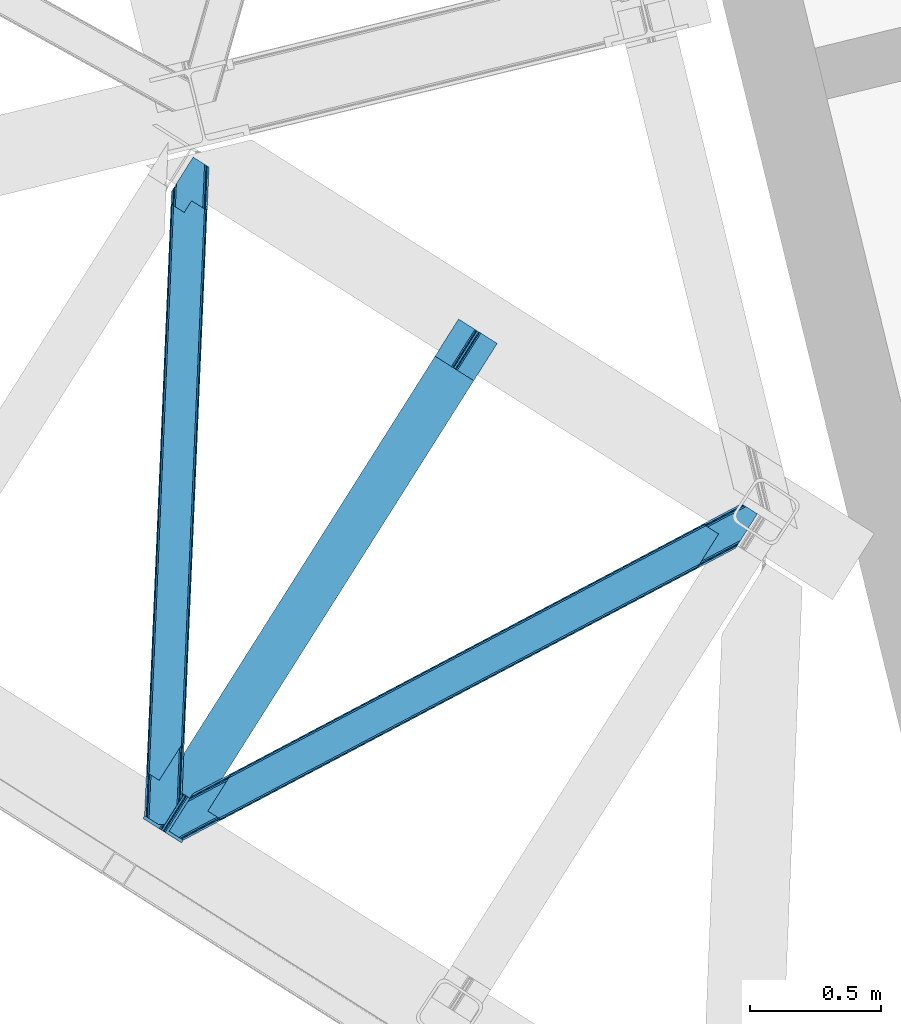
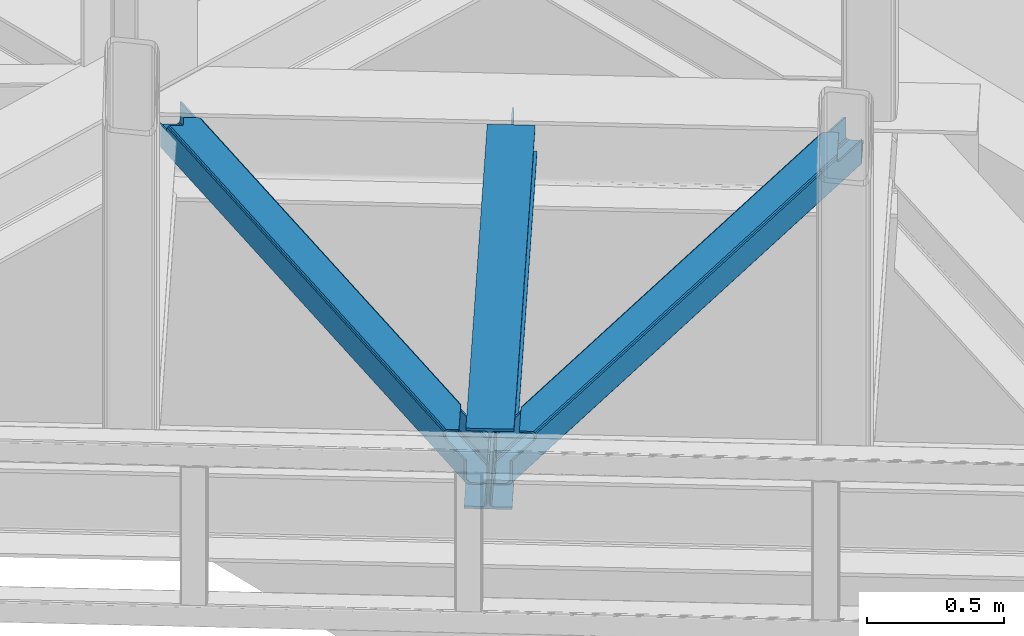
# One storey, part 72 of 93: 2 members, 1 beam.
"""IFC4 building model written with IfcOpenShell, lengths in millimetres."""

from ifc_helpers import new_model, entity, si_unit, converted_unit, derived_unit, direction, frame, origin, place, context, subcontext, project, spatial, triangles, polygons, material, type_object, element, save


model = new_model("IFC4")

# Units and contexts
model_context = context("Model", 3, precision=0.01, world=origin(), true_north=direction((6.12303176911189e-17, 1.0)))
plan_context = context("Plan", 3, precision=0.01, world=origin(), true_north=direction((6.12303176911189e-17, 1.0)))
body_context = subcontext(model_context, "Body", "Model", "MODEL_VIEW")
ifc_project = project(units=[si_unit("LENGTHUNIT", "METRE", prefix="MILLI"), si_unit("AREAUNIT", "SQUARE_METRE"), si_unit("VOLUMEUNIT", "CUBIC_METRE"), converted_unit("PLANEANGLEUNIT", "DEGREE", entity("IfcRatioMeasure", 0.0174532925199433), si_unit("PLANEANGLEUNIT", "RADIAN"), dimensions=[0, 0, 0, 0, 0, 0, 0]), si_unit("MASSUNIT", "GRAM", prefix="KILO"), derived_unit("MASSDENSITYUNIT", [(si_unit("MASSUNIT", "GRAM", prefix="KILO"), 1), (si_unit("LENGTHUNIT", "METRE"), -3)]), derived_unit("MOMENTOFINERTIAUNIT", [(si_unit("LENGTHUNIT", "METRE"), 4)]), si_unit("TIMEUNIT", "SECOND"), si_unit("FREQUENCYUNIT", "HERTZ"), si_unit("THERMODYNAMICTEMPERATUREUNIT", "DEGREE_CELSIUS"), derived_unit("THERMALTRANSMITTANCEUNIT", [(si_unit("MASSUNIT", "GRAM", prefix="KILO"), 1), (si_unit("THERMODYNAMICTEMPERATUREUNIT", "KELVIN"), -1), (si_unit("TIMEUNIT", "SECOND"), -3)]), derived_unit("VOLUMETRICFLOWRATEUNIT", [(si_unit("LENGTHUNIT", "METRE"), 3), (si_unit("TIMEUNIT", "SECOND"), -1)]), derived_unit("MASSFLOWRATEUNIT", [(si_unit("MASSUNIT", "GRAM", prefix="KILO"), 1), (si_unit("TIMEUNIT", "SECOND"), -1)]), derived_unit("ROTATIONALFREQUENCYUNIT", [(si_unit("TIMEUNIT", "SECOND"), -1)]), si_unit("ELECTRICCURRENTUNIT", "AMPERE"), si_unit("ELECTRICVOLTAGEUNIT", "VOLT"), si_unit("POWERUNIT", "WATT"), si_unit("FORCEUNIT", "NEWTON", prefix="KILO"), si_unit("ILLUMINANCEUNIT", "LUX"), si_unit("LUMINOUSFLUXUNIT", "LUMEN"), si_unit("LUMINOUSINTENSITYUNIT", "CANDELA"), derived_unit("USERDEFINED", [(si_unit("MASSUNIT", "GRAM", prefix="KILO"), -1), (si_unit("LENGTHUNIT", "METRE"), -2), (si_unit("TIMEUNIT", "SECOND"), 3), (si_unit("LUMINOUSFLUXUNIT", "LUMEN"), 1)]), derived_unit("LINEARVELOCITYUNIT", [(si_unit("LENGTHUNIT", "METRE"), 1), (si_unit("TIMEUNIT", "SECOND"), -1)]), si_unit("PRESSUREUNIT", "PASCAL"), derived_unit("USERDEFINED", [(si_unit("LENGTHUNIT", "METRE"), -2), (si_unit("MASSUNIT", "GRAM", prefix="KILO"), 1), (si_unit("TIMEUNIT", "SECOND"), -2)]), derived_unit("LINEARFORCEUNIT", [(si_unit("MASSUNIT", "GRAM", prefix="KILO"), 1), (si_unit("LENGTHUNIT", "METRE"), 1), (si_unit("TIMEUNIT", "SECOND"), -2), (si_unit("LENGTHUNIT", "METRE"), -1)]), derived_unit("PLANARFORCEUNIT", [(si_unit("MASSUNIT", "GRAM", prefix="KILO"), 1), (si_unit("LENGTHUNIT", "METRE"), 1), (si_unit("TIMEUNIT", "SECOND"), -2), (si_unit("LENGTHUNIT", "METRE"), -2)])], contexts=[model_context, plan_context])

# Site, building, storey
site_placement = place(None, origin())
site = spatial("IfcSite", under=ifc_project, at=site_placement, CompositionType="ELEMENT")
building_placement = place(site_placement, origin())
building = spatial("IfcBuilding", under=site, at=building_placement, CompositionType="ELEMENT")
storey_placement = place(building_placement, frame((0.0, 0.0, 15900.0)))
storey = spatial("IfcBuildingStorey", under=building, at=storey_placement, CompositionType="ELEMENT", Elevation=15900.0)

# Beam
ifc_material = material(Name="Metal painted (White)")
beam_type = type_object("IfcBeamType", PredefinedType="BEAM")
beam_placement = place(storey_placement, frame((-2373.14584361384, 14260.2889328785, 3441.0)))
element("IfcBeam", 1, at=beam_placement, inside=storey, type_object=beam_type, material=ifc_material, ObjectType="Steel Beam", PredefinedType="BEAM", context=body_context, shape_type="Tessellation", body=[
    polygons([(147.919660694801, 2.16573425859679e-12, 11.000000000004), (147.919660694804, 4.33146851719357e-12, 2.16573425859679e-12), (1355.44607863557, 1910.06544717356, 2.16573425859679e-12), (1355.44607863557, 1910.06544717355, 11.000000000004), (90.4423068248279, 36.3366728266057, 11.0000000000062), (1297.96872476558, 1946.40212000016, 11.0000000000062), (85.2668642219479, 39.6085416920184, 12.2179274798195), (1292.7932821627, 1949.67398886557, 12.2179274798195), (80.879335839855, 42.3822981822298, 15.6862915010278), (1288.40575378062, 1952.44774535578, 15.6862915010235), (77.9476831016699, 44.2356630157985, 20.8770650821592), (1285.47410104242, 1954.30111018934, 20.8770650821592), (76.9182235613, 44.8864781975669, 27.0000000000047), (1284.44464150205, 1954.95192537111, 27.0000000000025), (1278.52785507426, 1958.69246522089, 27.0000000000047), (1278.52785507432, 1958.69246522022, 203.000000000006), (1284.44464150196, 1954.95192537085, 203.000000000006), (1207.52641794078, 2003.57894341848, 2.16573425859679e-12), (1207.52641794077, 2003.57894341847, 10.9999999999997), (1265.00377181074, 1967.24227059188, 11.000000000004), (1270.17921441362, 1963.97040172646, 12.2179274798174), (1274.56674279571, 1961.19664523624, 15.686291501017), (1277.49839553388, 1959.34328040268, 20.8770650821613), (76.9182235613823, 44.8864781975192, 203.000000000006), (71.0014371335516, 48.6270180473361, 203.000000000006), (71.0014371335062, 48.6270180473665, 27.0000000000047), (69.9719775931376, 49.2778332291413, 20.8770650821657), (67.0403248549568, 51.1311980626949, 15.686291501017), (62.6527964728682, 53.904954552915, 12.2179274798174), (57.4773538699869, 57.176823418332, 11.000000000004), (8.12150346973795e-12, 93.5134962449225, 10.9999999999997), (5.41433564649196e-12, 93.5134962449269, 2.16573425859679e-12), (162.887980343835, 180.873386503032, 203.069792575797), (1195.07248712349, 1813.58297531797, 203.006342981534), (1194.53809439775, 1812.73773730252, 217.000000000003), (163.217821525431, 181.395193639939, 217.000000000003), (163.217821525544, 181.395193639874, 204.000000000014), (156.766642341062, 184.290495421957, 203.006342980148), (157.301035097542, 185.135733489758, 217.000000000003), (1188.62130797009, 1816.4782771522, 217.000000000003), (1188.6213079702, 1816.47827715213, 204.00000000001), (1188.95114918025, 1817.00008434255, 203.069791966823), (157.301035097816, 185.135733489578, 204.000000000014), (164.247281065643, 180.744378458268, 223.122934917846), (167.178933803825, 178.891013624723, 228.313708498988), (171.566462185928, 176.117257134518, 231.782072520181), (176.741904788822, 172.845388269138, 232.999999999999), (234.219258658959, 136.508715442803, 233.000000000003), (234.219258658962, 136.508715442803, 244.000000000005), (86.2995979637529, 230.022211687052, 244.000000000005), (86.2995979637521, 230.022211687052, 232.999999999999), (143.776951833897, 193.685538860712, 233.000000000003), (148.952394436777, 190.413669995315, 231.78207252019), (153.339922818875, 187.63991350511, 228.313708498988), (156.271575557062, 185.786548671563, 223.12293491785), (1187.59184842946, 1817.12909233409, 223.12293491785), (1184.66019569129, 1818.98245716763, 228.313708498988), (1180.27266730917, 1821.75621365784, 231.78207252019), (1175.0972247063, 1825.02808252324, 233.000000000003), (1117.61987083616, 1861.36475534957, 232.999999999999), (1117.61987083616, 1861.36475534957, 244.000000000005), (1265.53953153138, 1767.85125910532, 244.000000000005), (1265.53953153137, 1767.85125910532, 233.000000000003), (1208.06217766123, 1804.18793193166, 233.000000000003), (1202.88673505832, 1807.45980079704, 231.782072520181), (1198.49920667623, 1810.23355728724, 228.313708498988), (1195.56755393804, 1812.08692212079, 223.122934917842), (1194.53809439802, 1812.73773730233, 204.00000000001)], [[[1, 2, 3, 4]], [[5, 1, 4, 6]], [[7, 5, 6, 8]], [[9, 7, 8, 10]], [[11, 9, 10, 12]], [[13, 11, 12, 14]], [[15, 16, 17, 14, 12, 10, 8, 6, 4, 3, 18, 19, 20, 21, 22, 23]], [[13, 24, 25, 26, 27, 28, 29, 30, 31, 32, 2, 1, 5, 7, 9, 11]], [[2, 32, 18, 3]], [[32, 31, 19, 18]], [[31, 30, 20, 19]], [[27, 26, 15, 23]], [[28, 27, 23, 22]], [[29, 28, 22, 21]], [[30, 29, 21, 20]], [[33, 24, 13, 14, 17, 34, 35, 36, 37]], [[25, 38, 39, 40, 41, 42, 16, 15, 26]], [[38, 25, 24, 33]], [[42, 34, 17, 16]], [[39, 43, 37, 36, 44, 45, 46, 47, 48, 49, 50, 51, 52, 53, 54, 55]], [[40, 56, 57, 58, 59, 60, 61, 62, 63, 64, 65, 66, 67, 35, 68, 41]], [[44, 36, 35, 67]], [[45, 44, 67, 66]], [[46, 45, 66, 65]], [[47, 46, 65, 64]], [[48, 47, 64, 63]], [[49, 48, 63, 62]], [[50, 49, 62, 61]], [[51, 50, 61, 60]], [[52, 51, 60, 59]], [[53, 52, 59, 58]], [[54, 53, 58, 57]], [[55, 54, 57, 56]], [[39, 55, 56, 40]]], closed=False),
])

# Members
member_type_1 = type_object("IfcMemberType", PredefinedType="BRACE")
member_1_placement = place(storey_placement, frame((-2272.77551651001, 14270.5231292725, 3541.00055236816)))
element("IfcMember", 2, at=member_1_placement, inside=storey, type_object=member_type_1, ObjectType="Steel Horizontal Brace", PredefinedType="BRACE", context=body_context, shape_type="Tessellation", body=[
    triangles([(2166.61486344337, 1116.62719116211, 112.998916625977), (2173.80174307823, 1127.99161376953, 112.998916625977), (2044.4205051899, 1059.94925537109, 112.998916625977), (2036.90270462036, 1048.05812072754, 112.998916625977), (2029.42218375206, 1044.1037109375, 113.836074829102), (2032.01686549187, 1053.39151611328, 115.498764038086), (2030.77495365143, 1052.79155273437, 116.284762573243), (2036.94003882408, 1055.99484558105, 113.836074829102), (2026.93752436638, 1051.31141052246, 119.789199829102), (2018.84619412422, 1038.51219177246, 119.789199829102), (2023.08254528046, 1040.75158996582, 116.221975708009), (2028.56100811958, 1051.72068786621, 117.687002563478), (2026.56859703064, 1052.01950683594, 122.196029663086), (2017.54004201889, 1037.82153625488, 122.500662231447), (2017.42678585053, 1037.83432617187, 124.000570678712), (2027.24235677719, 1053.36012268066, 124.000570678712), (200.000582885742, 78.5370666503895, 129.195602416992), (201.301375579834, 77.717349243163, 122.500662231447), (2018.78793096542, 1039.9888458252, 129.195602416992), (2022.86099267006, 1046.4326385498, 134.874325561523), (196.304878234863, 80.8741333007802, 134.874325561523), (2028.95898528099, 1056.07856140137, 138.667117309571), (190.775273895264, 84.3727569580078, 138.667117309571), (2036.15227804184, 1067.45577392578, 139.999594116212), (184.250090789795, 88.4980865478501, 139.999594116212), (193.497927474975, 81.5101409912095, 114.866244506837), (194.136696624756, 82.2473052978512, 118.998550415039), (192.620655441284, 83.2042236328125, 121.889071655274), (189.485236358642, 85.1866607666016, 127.874752807616), (2030.37881140709, 1058.32493591309, 127.874752807616), (2043.67013311386, 1079.34690856934, 133.000021362306), (2036.47684035301, 1067.96969604492, 131.667544555665), (177.425943374634, 92.8094512939442, 133.000021362306), (183.951126480103, 88.6841217041001, 131.667544555665), (201.301375579834, 77.717349243163, 118.998550415039), (148.082821655273, 111.360644531249, 139.999594116212), (148.082821655273, 111.360644531249, 133.000021362306), (2101.84745049477, 1171.37268676758, 139.999594116212), (2101.84745049477, 1171.37268676758, 133.000021362306), (2059.13757562637, 1198.37336425781, 139.999594116212), (220.991888809204, 226.688488769531, 139.999594116212), (2065.9571993351, 1194.06083679199, 133.000021362306), (213.474033737183, 214.797354125976, 133.000021362306), (226.76537361145, 235.819326782226, 127.874752807616), (228.185199737549, 238.066864013672, 138.667117309571), (220.667344665527, 226.17456665039, 131.667544555665), (234.283228683472, 247.711624145508, 134.874325561523), (229.901810073852, 240.784140014648, 124.000570678712), (238.35623588562, 254.155416870117, 129.195602416992), (239.717344665527, 256.309936523438, 124.000570678712), (2043.38265066147, 1208.33322143555, 129.195602416992), (2042.08625450134, 1209.1541015625, 122.500662231447), (239.604124832153, 256.322726440429, 122.500662231447), (2052.6124288559, 1202.49985656738, 138.667117309571), (2047.07826447487, 1205.99615478516, 134.874325561523), (2053.90241189003, 1201.68479003906, 127.874752807616), (2059.43205256462, 1198.18732910156, 131.667544555665), (2050.76254177094, 1203.66722717285, 121.889071655274), (2049.25095162392, 1204.62414550781, 118.998550415039), (2042.08625450134, 1209.1541015625, 118.998550415039), (230.575606155395, 242.124755859375, 122.196029663086), (2049.88982977867, 1205.36130981445, 114.866244506837), (228.587500762939, 242.424737548827, 117.689328002929), (226.52614402771, 241.474795532225, 116.221975708009), (230.206587982178, 242.832852172851, 119.789199829102), (225.127246856689, 240.752746582031, 115.498764038086), (238.297954559326, 255.632070922851, 119.789199829102), (234.061585235596, 253.392672729491, 116.221975708009), (227.722001266479, 250.040551757811, 113.836074829102), (220.204146194458, 238.149417114257, 113.836074829102), (220.241498565674, 246.087304687499, 112.998916625977), (212.723643493652, 234.195007324219, 112.998916625977), (199.660342025757, 76.8499603271484, 115.110415649415), (198.014802932739, 75.9802459716793, 111.222280883791), (190.089123916626, 71.7909667968743, 107.999221801758), (194.054288864136, 73.8861877441395, 109.610751342774), (187.230141448974, 78.1975524902336, 109.610751342774), (183.269482040405, 76.1034942626939, 107.999221801758), (191.195161056518, 80.2927734374989, 111.222280883791), (2045.36841244698, 1210.89004211426, 111.222280883791), (2043.72734255791, 1210.02265319824, 115.110415649415), (2052.1880361557, 1206.57751464844, 111.222280883791), (2056.15312843323, 1208.6727355957, 109.610751342774), (2049.3335047245, 1212.98526306152, 109.610751342774), (2060.11818437576, 1210.7691192627, 107.999221801758), (2053.2940369606, 1215.08048400879, 107.999221801758), (54.2830238342285, 0.0, 107.999221801758), (47.4635272979735, 4.31252746581958, 107.999221801758), (2166.61486344337, 1116.62719116211, 17.5000946044929), (54.2830238342285, 0.0, 17.5000946044929), (2032.0435353756, 1053.34151916504, 115.498764038086), (2174.14860599041, 1128.49274597168, 24.4996673583992), (191.196323776245, 80.2881225585934, 111.222280883791), (2173.68541660309, 1128.21253051758, 112.998916625977), (2044.44708423615, 1059.89925842285, 112.998916625977), (2174.16452071667, 1128.46716613769, 112.133853149415), (2036.96659970284, 1055.94484863281, 113.836074829102), (47.4478305816651, 4.3381072998036, 24.4996673583992), (183.2703540802, 76.1000061035156, 107.999221801758), (187.235664367676, 78.1940643310536, 109.610751342774), (47.4633819580076, 4.31369018554688, 107.999221801758), (193.499235534668, 81.5043273925767, 114.866244506837), (2185.41397941113, 1146.35793457031, 0.0), (2178.22067756653, 1134.9807220459, 1.33131408691406), (37.2317390441895, 10.7807373046871, 0.0), (43.7569221496583, 6.65540771484302, 1.33131408691406), (2172.12263953686, 1125.33479919434, 5.12526855468604), (49.2910320281981, 3.15910949706995, 5.12526855468604), (2168.04959599972, 1118.89100646973, 10.8028289794929), (52.9867366790772, 0.822042846679324, 10.8028289794929), (2174.1327185154, 1128.51832580566, 24.4996673583992), (2175.56744198799, 1130.78330383301, 17.8024017333992), (46.1670948028564, 5.13457031249891, 17.8024017333992), (47.4635272979735, 4.31252746581958, 24.4996673583992), (2179.64049460888, 1137.22709655762, 12.1248413085923), (42.4668846130371, 7.47047424316406, 12.1248413085923), (2185.7385235548, 1146.87185668945, 8.3320495605476), (36.9372802734374, 10.9679351806626, 8.3320495605476), (2192.93179814816, 1158.25023193359, 6.99957275390625), (30.4120971679686, 15.0932647705067, 6.99957275390625), (2249.93033573627, 1248.41333312988, 6.99957275390625), (2249.93033573627, 1248.41333312988, 0.0), (2174.1327185154, 1128.51832580566, 112.133853149415), (2195.92426629066, 1282.55892333984, 107.999221801758), (2189.1001188755, 1286.87028808594, 107.999221801758), (0.0, 34.3199981689449, 6.99957275390625), (0.0, 34.3199981689449, 0.0), (90.5293579101563, 177.517071533202, 112.998916625977), (83.0115028381347, 165.625936889648, 112.998916625977), (2189.1001188755, 1286.87028808594, 17.5000946044929), (90.5293579101563, 177.517071533202, 17.5000946044929), (2206.15144000053, 1276.08955078125, 0.0), (71.730214691162, 147.786328124999, 0.0), (2190.40098423958, 1286.05057067871, 10.8028289794929), (89.0945617675779, 175.253256225586, 10.8028289794929), (2194.09663438797, 1283.71350402832, 5.12526855468604), (85.0214092254637, 168.809463500977, 5.12526855468604), (2199.62629323006, 1280.21488037109, 1.33131408691406), (78.9233802795411, 159.163540649413, 1.33131408691406), (2200.91626263857, 1279.4009765625, 12.1248413085923), (2212.97554653883, 1271.77818603516, 6.99957275390625), (2206.45043610334, 1275.903515625, 8.3320495605476), (2195.92426629066, 1282.55892333984, 24.4996673583992), (2197.2206079483, 1281.73804321289, 17.8024017333992), (83.0115028381347, 165.625936889648, 24.4996673583992), (81.5767066955564, 163.360958862304, 17.8024017333992), (77.503699493408, 156.917166137695, 12.1248413085923), (64.2123596191404, 135.894030761718, 6.99957275390625), (71.4056705474854, 147.272406005859, 8.3320495605476)], [[1, 2, 3], [3, 4, 1], [5, 6, 7], [5, 8, 6], [9, 10, 11], [11, 7, 12], [13, 14, 10], [13, 15, 14], [10, 9, 13], [13, 16, 15], [11, 12, 9], [7, 11, 5], [3, 8, 4], [5, 4, 8], [15, 17, 18], [18, 14, 15], [15, 19, 17], [19, 20, 21], [21, 17, 19], [20, 22, 23], [23, 21, 20], [22, 24, 25], [25, 23, 22], [26, 9, 12], [7, 6, 26], [26, 12, 7], [9, 26, 27], [27, 13, 9], [27, 28, 13], [29, 30, 16], [16, 28, 29], [16, 13, 28], [31, 32, 33], [34, 33, 32], [32, 30, 34], [29, 34, 30], [21, 29, 23], [28, 17, 18], [18, 35, 27], [27, 28, 18], [29, 17, 28], [21, 17, 29], [34, 25, 23], [23, 29, 34], [34, 33, 25], [33, 36, 25], [37, 36, 33], [32, 22, 30], [38, 31, 39], [31, 38, 24], [32, 24, 22], [32, 31, 24], [20, 16, 30], [22, 20, 30], [16, 20, 19], [15, 16, 19], [24, 40, 41], [24, 38, 40], [41, 25, 24], [36, 25, 41], [42, 31, 43], [31, 42, 39], [33, 43, 31], [37, 43, 33], [44, 45, 46], [47, 48, 49], [44, 47, 45], [49, 48, 50], [47, 44, 48], [46, 45, 41], [36, 43, 41], [37, 43, 36], [43, 46, 41], [50, 51, 52], [52, 53, 50], [40, 54, 45], [45, 41, 40], [54, 55, 47], [47, 45, 54], [55, 51, 49], [49, 47, 55], [50, 49, 51], [56, 54, 55], [39, 38, 42], [38, 40, 42], [54, 57, 40], [56, 57, 54], [57, 42, 40], [51, 58, 56], [55, 51, 56], [58, 51, 52], [52, 59, 58], [52, 60, 59], [56, 44, 48], [48, 58, 56], [48, 61, 58], [62, 63, 64], [62, 65, 63], [64, 66, 62], [65, 62, 59], [59, 61, 65], [59, 58, 61], [56, 57, 44], [46, 44, 57], [57, 42, 46], [43, 46, 42], [61, 53, 67], [61, 50, 53], [67, 65, 61], [65, 67, 68], [68, 64, 63], [69, 66, 64], [69, 70, 66], [69, 71, 70], [72, 70, 71], [64, 68, 69], [68, 63, 65], [61, 48, 50], [27, 26, 73], [73, 35, 27], [74, 73, 26], [75, 76, 77], [77, 78, 75], [76, 74, 79], [79, 77, 76], [26, 79, 74], [80, 81, 62], [59, 62, 81], [81, 60, 59], [62, 82, 80], [82, 83, 84], [84, 80, 82], [83, 85, 86], [86, 84, 83], [75, 78, 87], [88, 87, 78], [11, 74, 89], [11, 10, 74], [14, 74, 10], [35, 73, 14], [35, 14, 18], [5, 11, 89], [89, 1, 4], [4, 5, 89], [90, 89, 74], [74, 14, 73], [74, 76, 90], [75, 90, 76], [90, 75, 87], [91, 92, 93], [94, 92, 95], [94, 96, 92], [91, 97, 92], [97, 95, 92], [93, 92, 98], [98, 99, 100], [98, 101, 99], [100, 93, 98], [93, 102, 91], [103, 104, 105], [106, 105, 104], [104, 107, 106], [108, 106, 107], [107, 109, 108], [110, 108, 109], [109, 89, 110], [90, 110, 89], [111, 112, 113], [113, 114, 111], [112, 115, 116], [116, 113, 112], [115, 117, 118], [118, 116, 115], [117, 119, 120], [120, 118, 117], [115, 107, 104], [115, 104, 117], [119, 117, 103], [112, 107, 115], [121, 119, 122], [103, 122, 119], [117, 104, 103], [109, 107, 112], [1, 89, 111], [111, 123, 1], [2, 1, 123], [109, 112, 89], [112, 111, 89], [124, 125, 85], [86, 85, 125], [110, 116, 108], [114, 90, 87], [87, 88, 114], [114, 113, 90], [113, 110, 90], [116, 110, 113], [106, 108, 116], [120, 105, 118], [116, 118, 106], [120, 126, 127], [118, 105, 106], [120, 127, 105], [72, 71, 128], [128, 129, 72], [80, 130, 131], [84, 130, 80], [125, 130, 86], [84, 86, 130], [60, 81, 53], [81, 80, 53], [52, 60, 53], [68, 80, 131], [131, 69, 68], [71, 69, 131], [131, 128, 71], [68, 67, 80], [67, 53, 80], [132, 103, 133], [103, 132, 122], [105, 133, 103], [127, 133, 105], [130, 134, 131], [135, 131, 134], [134, 136, 135], [137, 135, 136], [136, 138, 137], [139, 137, 138], [138, 132, 139], [133, 139, 132], [140, 138, 136], [121, 122, 141], [122, 132, 141], [138, 142, 132], [140, 142, 138], [142, 141, 132], [130, 143, 144], [134, 140, 136], [140, 134, 144], [134, 130, 144], [125, 143, 130], [125, 124, 143], [143, 82, 145], [83, 82, 143], [82, 62, 66], [143, 85, 83], [85, 143, 124], [145, 82, 66], [66, 70, 145], [72, 145, 70], [145, 72, 129], [137, 146, 147], [145, 131, 128], [128, 129, 145], [145, 146, 131], [146, 135, 131], [146, 137, 135], [139, 137, 147], [148, 133, 149], [147, 149, 139], [148, 126, 127], [149, 133, 139], [148, 127, 133], [119, 141, 148], [119, 121, 141], [148, 120, 119], [126, 120, 148], [141, 142, 149], [149, 148, 141], [142, 140, 147], [147, 149, 142], [140, 144, 146], [146, 147, 140], [144, 143, 145], [145, 146, 144]]),
])
member_type_2 = type_object("IfcMemberType", PredefinedType="BRACE")
member_2_placement = place(storey_placement, frame((-2366.79041748047, 14329.5497589111, 3541.00055236816)))
element("IfcMember", 3, at=member_2_placement, inside=storey, type_object=member_type_2, ObjectType="Steel Horizontal Brace", PredefinedType="BRACE", context=body_context, shape_type="Tessellation", body=[
    triangles([(100.655629348755, 2374.38995361328, 112.998916625977), (107.475271224976, 2370.07742614746, 112.998916625977), (102.696783828736, 2421.82891845703, 112.998916625977), (109.879194259644, 2433.19217834473, 112.998916625977), (110.120894622803, 2433.18287658691, 112.998916625977), (107.407542800903, 2370.08091430664, 112.998916625977), (110.142259597778, 2433.72354125977, 112.133853149415), (107.407397460938, 2370.08091430664, 115.498764038086), (13.930835723877, 195.896182250977, 115.498764038086), (110.180774688721, 2433.72237854004, 24.4996673583992), (13.8035179138183, 192.844042968751, 111.222280883791), (6.85336074829092, 30.4120971679695, 24.4996673583992), (13.6123958587646, 188.365246582032, 109.610751342774), (13.4169136047362, 183.884124755859, 107.999221801758), (6.81949653625497, 30.4144226074222, 107.999221801758), (0.0, 34.7257873535164, 107.999221801758), (6.82414741516141, 30.4144226074222, 107.999221801758), (13.4262153625491, 183.885287475587, 107.999221801758), (6.6020679473877, 188.196652221681, 107.999221801758), (6.98896293640155, 197.155407714845, 111.222280883791), (13.808604812622, 192.842880249023, 111.222280883791), (13.9405735015871, 195.89501953125, 115.498764038086), (14.3164226531985, 196.336853027344, 118.998550415039), (7.14723815917978, 200.865646362305, 118.998550415039), (7.06817321777362, 199.011108398438, 115.110415649415), (13.6174827575683, 188.364083862305, 109.610751342774), (6.79784088134784, 192.676611328125, 109.610751342774), (15.8281036376952, 195.378771972657, 121.889071655274), (108.771703720093, 2369.25654602051, 122.196029663086), (112.471768569947, 2366.92064208984, 127.874752807616), (107.475271224976, 2370.07742614746, 115.498764038086), (18.9633773803712, 193.396334838868, 127.874752807616), (118.001518249512, 2363.42318115235, 131.667544555665), (24.4974872589114, 189.900036621095, 131.667544555665), (124.526556015015, 2359.29668884277, 133.000021362306), (31.0226703643798, 185.773544311523, 133.000021362306), (129.009131240845, 2463.45079650879, 6.99957275390625), (121.8158203125, 2452.07358398438, 8.3320495605476), (23.8754322052005, 19.6336853027351, 6.99957275390625), (17.3502490997316, 23.7590148925792, 8.3320495605476), (115.717791366577, 2442.42882385254, 12.1248413085923), (11.8161392211914, 27.2564758300778, 12.1248413085923), (111.644784164429, 2435.9838684082, 17.8024017333992), (8.12043457031268, 29.5935424804684, 17.8024017333992), (110.214638900757, 2433.72121582031, 24.4996673583992), (6.82414741516141, 30.4144226074222, 24.4996673583992), (102.696783828736, 2421.82891845703, 17.5000946044929), (100.655629348755, 2374.38995361328, 122.500662231447), (7.14723815917978, 200.865646362305, 122.500662231447), (0.0, 34.7257873535164, 17.5000946044929), (117.706914138794, 2363.6092163086, 139.999594116212), (111.181876373291, 2367.73570861817, 138.667117309571), (17.6778453826905, 194.212564086914, 138.667117309571), (24.2030284881594, 190.086071777345, 139.999594116212), (105.647621154785, 2371.23200683594, 134.874325561523), (12.1437355041503, 197.708862304688, 134.874325561523), (101.952061843872, 2373.56907348633, 129.195602416992), (8.44817619323749, 200.045928955078, 129.195602416992), (151.68507270813, 2342.12680664063, 133.000021362306), (151.68507270813, 2342.12680664063, 139.999594116212), (56.1432300567626, 169.89428100586, 133.000021362306), (56.1432300567626, 169.89428100586, 139.999594116212), (104.126929092407, 2424.09273376465, 10.8028289794929), (1.30093803405771, 33.9060699462898, 10.8028289794929), (108.200081634522, 2430.53652648926, 5.12526855468604), (4.99649734497098, 31.5690032958992, 5.12526855468604), (114.298110580444, 2440.18244934082, 1.33131408691406), (10.5307525634767, 28.0715423583988, 1.33131408691406), (121.491276168823, 2451.55966186523, 0.0), (17.0557903289796, 23.9462127685547, 0.0), (186.00768699646, 2553.61506042481, 6.99957275390625), (186.00768699646, 2553.61506042481, 0.0), (110.214638900757, 2433.72121582031, 112.133853149415), (53.3593883514404, 0.995288085938228, 6.99957275390625), (53.3593883514404, 0.995288085938228, 0.0), (76.5082660675048, 0.0, 0.0), (76.5082660675048, 0.0, 6.99957275390625), (124.379326629639, 75.7232849121101, 0.0), (229.786700820923, 2525.94000549316, 0.0), (116.861471557617, 63.8309875488285, 6.99957275390625), (222.967058944702, 2530.25253295898, 6.99957275390625), (236.311738586426, 2521.8135131836, 1.33131408691406), (131.572637557983, 87.1004974365242, 1.33131408691406), (241.845993804932, 2518.31721496582, 5.12526855468604), (137.670666503906, 96.7452575683601, 5.12526855468604), (245.541553115845, 2515.98014831543, 10.8028289794929), (141.743673706055, 103.190213012696, 10.8028289794929), (246.837985610962, 2515.15926818848, 17.5000946044929), (143.173964309693, 105.452865600586, 17.5000946044929), (240.018343734741, 2519.4717956543, 24.4996673583992), (238.721911239624, 2520.29267578125, 17.8024017333992), (135.656109237671, 93.5605682373043, 24.4996673583992), (134.225963973999, 91.2979156494148, 17.8024017333992), (235.026351928711, 2522.62974243164, 12.1248413085923), (130.152811431885, 84.8529602050785, 12.1248413085923), (229.492096710205, 2526.12604064941, 8.3320495605476), (124.054782485962, 75.2082000732426, 8.3320495605476), (143.173964309693, 105.452865600586, 107.999221801758), (135.656109237671, 93.5605682373043, 107.999221801758), (246.837985610962, 2515.15926818848, 107.999221801758), (240.018343734741, 2519.4717956543, 107.999221801758), (144.900748443604, 308.420709228516, 107.999221801758), (152.418603515625, 320.313006591798, 107.999221801758), (233.416130447388, 2366.00093078613, 107.999221801758), (240.235772323609, 2361.68840332031, 107.999221801758), (233.02938079834, 2357.04217529297, 111.222280883791), (233.225008392334, 2361.52213439942, 109.610751342774), (232.901917648316, 2353.99003601074, 115.498764038086), (144.985917663574, 310.428726196289, 108.999160766602), (144.943333053589, 309.42413635254, 108.49919128418), (144.985917663574, 310.428726196289, 115.498764038086), (143.555627059937, 308.164910888672, 122.196029663086), (152.50362739563, 322.321023559571, 122.500662231447), (151.073482131958, 320.057208251954, 129.195602416992), (147.00047492981, 313.613415527345, 134.874325561523), (139.482619857788, 301.721118164063, 127.874752807616), (152.50362739563, 322.321023559571, 108.999160766602), (140.902445983887, 303.967492675782, 138.667117309571), (133.384590911865, 292.076358032227, 131.667544555665), (133.709135055542, 292.590280151368, 139.999594116212), (126.19127998352, 280.697982788086, 133.000021362306), (239.853528213501, 2352.73081054688, 111.222280883791), (239.774317932129, 2350.87510986328, 115.110415649415), (240.044650268555, 2357.20960693359, 109.610751342774), (239.690747451783, 2349.01940917969, 118.998550415039), (239.690747451783, 2349.01940917969, 122.500662231447), (152.461188125611, 321.316433715821, 108.49919128418), (222.639462661743, 2359.80014648438, 139.999594116212), (179.929569625855, 2386.80082397461, 139.999594116212), (215.819820785523, 2364.1126739502, 133.000021362306), (179.929569625855, 2386.80082397461, 133.000021362306), (234.698755645752, 2352.17735595703, 134.874325561523), (227.879113769531, 2356.48988342285, 127.874752807616), (229.164500427246, 2355.67365417481, 138.667117309571), (231.014387512207, 2354.50628356934, 121.889071655274), (238.394314956665, 2349.84028930664, 129.195602416992), (232.526068496704, 2353.54936523438, 118.998550415039), (222.344858551025, 2359.98618164063, 131.667544555665)], [[1, 2, 3], [4, 3, 2], [5, 6, 7], [6, 8, 9], [6, 10, 7], [6, 11, 10], [9, 11, 6], [12, 10, 11], [13, 12, 11], [12, 13, 14], [15, 12, 14], [16, 17, 18], [18, 19, 16], [20, 21, 22], [23, 24, 25], [25, 22, 23], [22, 25, 20], [26, 21, 27], [20, 27, 21], [18, 26, 19], [27, 19, 26], [28, 29, 30], [29, 28, 23], [23, 31, 29], [23, 22, 31], [30, 32, 28], [30, 33, 32], [34, 32, 33], [33, 35, 34], [36, 34, 35], [37, 38, 39], [40, 39, 38], [38, 41, 40], [42, 40, 41], [41, 43, 42], [44, 42, 43], [43, 45, 44], [46, 44, 45], [1, 25, 24], [47, 20, 1], [1, 3, 47], [24, 48, 1], [49, 48, 24], [20, 47, 50], [50, 19, 27], [50, 16, 19], [27, 20, 50], [20, 25, 1], [51, 52, 53], [53, 54, 51], [52, 55, 56], [56, 53, 52], [55, 57, 58], [58, 56, 55], [57, 48, 49], [49, 58, 57], [30, 52, 55], [59, 60, 35], [60, 51, 35], [52, 33, 51], [30, 33, 52], [33, 35, 51], [48, 31, 29], [57, 30, 55], [30, 57, 29], [57, 48, 29], [1, 31, 48], [1, 2, 31], [32, 53, 56], [61, 62, 36], [62, 54, 36], [53, 34, 54], [32, 34, 53], [34, 36, 54], [58, 28, 32], [56, 58, 32], [28, 58, 49], [49, 23, 28], [49, 24, 23], [47, 63, 64], [64, 50, 47], [63, 65, 66], [66, 64, 63], [65, 67, 68], [68, 66, 65], [67, 69, 70], [70, 68, 67], [41, 65, 67], [41, 67, 38], [37, 38, 69], [43, 65, 41], [71, 37, 72], [69, 72, 37], [38, 67, 69], [63, 65, 43], [3, 47, 45], [45, 73, 3], [4, 3, 73], [63, 43, 47], [43, 45, 47], [68, 42, 66], [40, 70, 39], [74, 39, 75], [40, 42, 68], [39, 70, 75], [40, 68, 70], [64, 66, 42], [16, 50, 46], [44, 46, 50], [17, 16, 46], [42, 44, 64], [44, 50, 64], [76, 77, 75], [74, 75, 77], [70, 78, 75], [78, 70, 69], [76, 75, 78], [69, 79, 78], [79, 69, 72], [74, 77, 80], [39, 80, 37], [80, 39, 74], [81, 37, 80], [81, 71, 37], [79, 82, 83], [83, 78, 79], [82, 84, 85], [85, 83, 82], [84, 86, 87], [87, 85, 84], [86, 88, 89], [89, 87, 86], [90, 91, 92], [93, 92, 91], [91, 94, 93], [95, 93, 94], [94, 96, 95], [97, 95, 96], [96, 81, 97], [80, 97, 81], [85, 93, 95], [92, 89, 98], [98, 99, 92], [92, 93, 89], [93, 87, 89], [93, 85, 87], [83, 85, 95], [80, 78, 97], [95, 97, 83], [80, 77, 76], [97, 78, 83], [80, 76, 78], [91, 90, 88], [88, 86, 91], [94, 86, 84], [86, 94, 91], [90, 100, 88], [90, 101, 100], [94, 84, 82], [96, 82, 79], [72, 81, 79], [71, 81, 72], [81, 96, 79], [96, 94, 82], [99, 98, 102], [103, 102, 98], [104, 105, 100], [100, 101, 104], [106, 90, 102], [104, 90, 107], [104, 101, 90], [108, 106, 109], [106, 107, 90], [110, 109, 106], [92, 102, 90], [92, 99, 102], [102, 110, 106], [109, 111, 108], [112, 111, 113], [113, 114, 112], [115, 112, 114], [112, 115, 116], [111, 117, 113], [111, 109, 117], [116, 115, 118], [119, 118, 120], [62, 121, 120], [61, 121, 62], [121, 119, 120], [119, 116, 118], [88, 122, 117], [123, 117, 122], [124, 122, 88], [88, 105, 124], [105, 88, 100], [103, 89, 88], [113, 125, 126], [88, 117, 127], [123, 125, 117], [117, 125, 113], [88, 127, 103], [89, 103, 98], [120, 51, 60], [51, 120, 54], [62, 54, 120], [60, 128, 120], [128, 60, 129], [121, 35, 59], [35, 121, 36], [61, 36, 121], [59, 130, 121], [130, 59, 131], [132, 133, 134], [135, 136, 126], [126, 125, 137], [137, 135, 126], [133, 136, 135], [132, 136, 133], [138, 128, 134], [134, 133, 138], [138, 130, 128], [130, 129, 128], [131, 129, 130], [133, 135, 112], [135, 137, 111], [111, 112, 135], [137, 108, 111], [112, 116, 133], [138, 133, 116], [116, 119, 138], [130, 138, 119], [119, 121, 130], [137, 125, 123], [122, 106, 108], [124, 105, 107], [104, 107, 105], [122, 124, 106], [107, 106, 124], [108, 123, 122], [123, 108, 137], [126, 136, 113], [114, 113, 136], [136, 132, 114], [115, 114, 132], [132, 134, 115], [118, 115, 134], [134, 128, 118], [120, 118, 128], [129, 131, 59], [59, 60, 129]]),
])

save(model, "model.ifc")
